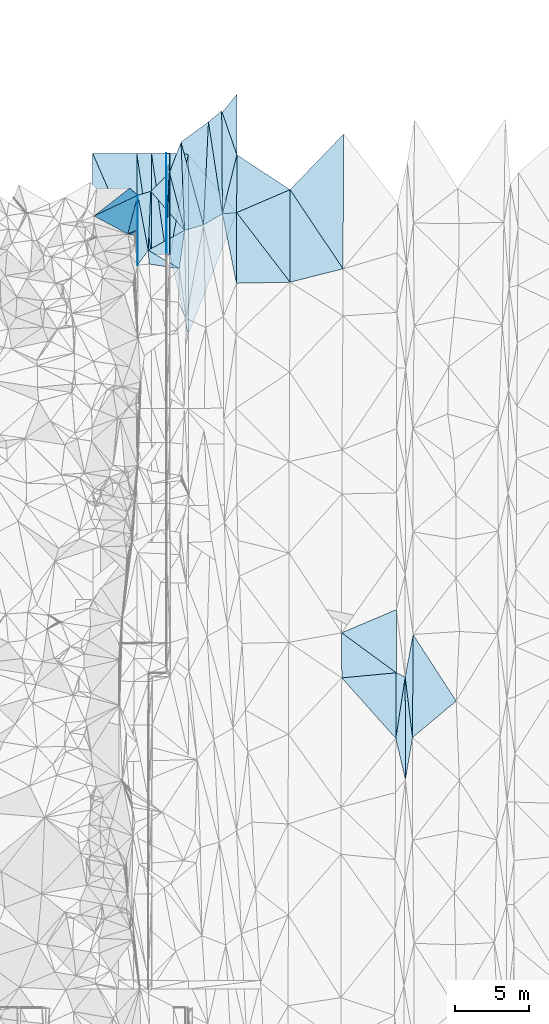
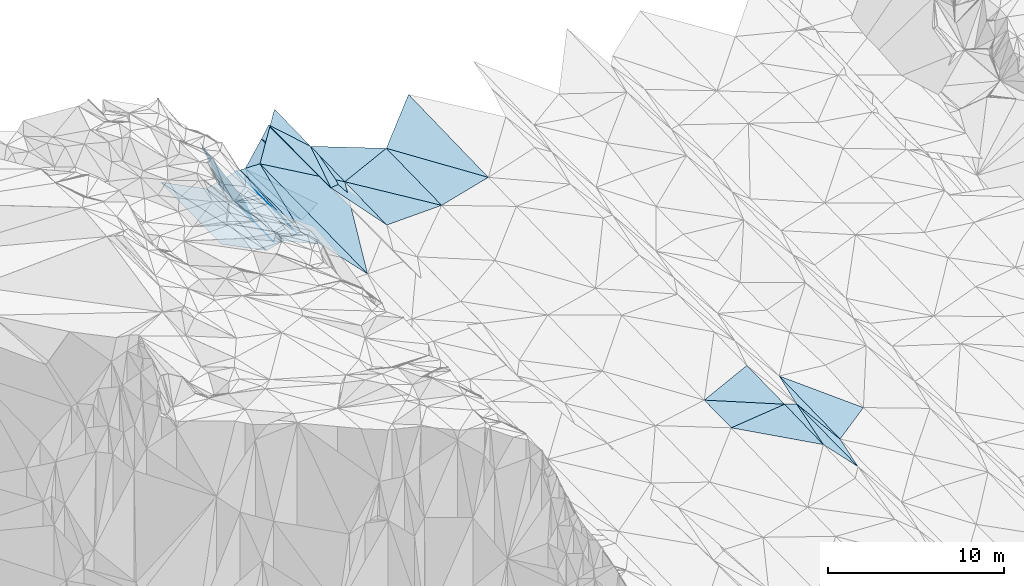
# One storey, part 144 of 275: 46 plates.
"""IFC2X3 building model written with IfcOpenShell, lengths in millimetres."""

from ifc_helpers import new_model, si_unit, frame, origin_with_axes, place, context, subcontext, project, spatial, polyline, outline, extrude, material, type_object, element, save


model = new_model("IFC2X3")

# Units and contexts
model_context = context("Model", 3, precision=1e-05, world=origin_with_axes())
body_context = subcontext(model_context, "Body", "Model", "MODEL_VIEW")
ifc_project = project(units=[si_unit("LENGTHUNIT", "METRE", prefix="MILLI"), si_unit("AREAUNIT", "SQUARE_METRE"), si_unit("VOLUMEUNIT", "CUBIC_METRE"), si_unit("MASSUNIT", "GRAM", prefix="KILO"), si_unit("TIMEUNIT", "SECOND"), si_unit("PLANEANGLEUNIT", "RADIAN"), si_unit("SOLIDANGLEUNIT", "STERADIAN"), si_unit("THERMODYNAMICTEMPERATUREUNIT", "DEGREE_CELSIUS"), si_unit("LUMINOUSINTENSITYUNIT", "LUMEN")], contexts=[model_context])

# Site, building, storey
site_placement = place(None, origin_with_axes())
site = spatial("IfcSite", under=ifc_project, at=site_placement, CompositionType="ELEMENT")
building_placement = place(site_placement, origin_with_axes())
building = spatial("IfcBuilding", under=site, at=building_placement, Name="Undefined", CompositionType="ELEMENT")
storey_placement = place(building_placement, origin_with_axes())
storey = spatial("IfcBuildingStorey", under=building, at=storey_placement, Name="Undefined", CompositionType="ELEMENT", Elevation=0.0)

# Plates
ifc_material = material()
plate_type_1 = type_object("IfcPlateType", PredefinedType="NOTDEFINED")
plate_1_placement = place(storey_placement, frame((-97590.6095144103, 136042.958184451, 44252.5008108323), z_axis=(0.0514832907805733, 0.0259882648043825, -0.998335655409973), x_axis=(-0.00443610332481202, -0.999645536783558, -0.0262511290424581)))
element("IfcPlate", 1, at=plate_1_placement, inside=storey, type_object=plate_type_1, material=ifc_material, Name="00", context=body_context, shape_type="SweptSolid", body=[
    extrude(outline(polyline([(0.0, 0.0), (4761.69970703125, 4.69444785267115e-08), (2378.60620117188, 10.8841924667358), (0.0, 0.0)])), frame((-8.85201319254618e-08, 2.18876761149539e-07, -0.5000001331573), z_axis=(0.0, 0.0, 1.0), x_axis=(1.0, 0.0, 0.0)), (0.0, 0.0, 1.0), 1.0),
])
plate_type_2 = type_object("IfcPlateType", PredefinedType="NOTDEFINED")
plate_2_placement = place(storey_placement, frame((-95411.9132426527, 131994.505825985, 43613.0622129509), z_axis=(0.0224822411046285, 0.0189781008891617, -0.999567096558082), x_axis=(0.179724849015763, 0.983454639409164, 0.0227145519624127)))
element("IfcPlate", 2, at=plate_2_placement, inside=storey, type_object=plate_type_2, material=ifc_material, Name="00_PR", context=body_context, shape_type="SweptSolid", body=[
    extrude(outline(polyline([(0.0, 0.0), (6942.90625, 5.26488292962313e-08), (-5108.5693359375, 2206.3701171875), (0.0, 0.0)])), frame((-8.85201319254618e-08, 2.18876761149539e-07, -0.5000001331573), z_axis=(0.0, 0.0, 1.0), x_axis=(1.0, 0.0, 0.0)), (0.0, 0.0, 1.0), 1.0),
])
plate_type_3 = type_object("IfcPlateType", PredefinedType="NOTDEFINED")
plate_3_placement = place(storey_placement, frame((-95664.109131725, 138888.552584876, 43729.3927088846), z_axis=(0.0499222322961073, 0.0186763581657816, -0.998578471812925), x_axis=(0.998752315665235, 0.000325866070990781, 0.0499370179790064)))
element("IfcPlate", 3, at=plate_3_placement, inside=storey, type_object=plate_type_3, material=ifc_material, Name="00_PR", context=body_context, shape_type="SweptSolid", body=[
    extrude(outline(polyline([(0.0, 0.0), (20.0252170562744, 7.18500814400613e-11), (13.5525465011597, 6895.32861328125), (0.0, 0.0)])), frame((-8.85201319254618e-08, 2.18876761149539e-07, -0.5000001331573), z_axis=(0.0, 0.0, 1.0), x_axis=(1.0, 0.0, 0.0)), (0.0, 0.0, 1.0), 1.0),
])
plate_4_placement = place(storey_placement, frame((-95641.8988715863, 131994.431588011, 43601.5627079431), z_axis=(0.0499222322961073, 0.0186763581657816, -0.998578471812925), x_axis=(-0.998752315521962, -0.000325847078123489, -0.0499370209684242)))
element("IfcPlate", 4, at=plate_4_placement, inside=storey, type_object=plate_type_3, material=ifc_material, Name="00_PR", context=body_context, shape_type="SweptSolid", body=[
    extrude(outline(polyline([(0.0, 0.0), (20.0252170562744, 7.18500814400613e-11), (13.5523777008057, 6895.32861328125), (0.0, 0.0)])), frame((-8.85201319254618e-08, 2.18876761149539e-07, -0.5000001331573), z_axis=(0.0, 0.0, 1.0), x_axis=(1.0, 0.0, 0.0)), (0.0, 0.0, 1.0), 1.0),
])
plate_type_4 = type_object("IfcPlateType", PredefinedType="NOTDEFINED")
plate_5_placement = place(storey_placement, frame((-96661.8032589634, 131994.104718569, 43350.5770069072), z_axis=(0.242490143071299, 0.0182037295266078, -0.969983069308214), x_axis=(-0.970142403271045, -0.000311047105442569, -0.242535813077531)))
element("IfcPlate", 5, at=plate_5_placement, inside=storey, type_object=plate_type_4, material=ifc_material, Name="00_PR", context=body_context, shape_type="SweptSolid", body=[
    extrude(outline(polyline([(0.0, 0.0), (1030.77563476563, 6.37373887002468e-09), (999.529357910156, 6895.2607421875), (0.0, 0.0)])), frame((-8.85201319254618e-08, 2.18876761149539e-07, -0.5000001331573), z_axis=(0.0, 0.0, 1.0), x_axis=(1.0, 0.0, 0.0)), (0.0, 0.0, 1.0), 1.0),
])
plate_6_placement = place(storey_placement, frame((-97664.0124157105, 138887.911618985, 43229.4070067982), z_axis=(0.242490143071299, 0.0182037295266078, -0.969983069308214), x_axis=(0.970142455388523, 0.000311440077304942, 0.242535604103411)))
element("IfcPlate", 6, at=plate_6_placement, inside=storey, type_object=plate_type_4, material=ifc_material, Name="00_PR", context=body_context, shape_type="SweptSolid", body=[
    extrude(outline(polyline([(0.0, 0.0), (1030.77648925781, -5.90807758271694e-09), (999.526672363281, 6895.26123046875), (0.0, 0.0)])), frame((-8.85201319254618e-08, 2.18876761149539e-07, -0.5000001331573), z_axis=(0.0, 0.0, 1.0), x_axis=(1.0, 0.0, 0.0)), (0.0, 0.0, 1.0), 1.0),
])
plate_7_placement = place(storey_placement, frame((-95661.8028117827, 131994.424829902, 43600.5770067178), z_axis=(0.242490143071299, 0.0182037295266078, -0.969983069308214), x_axis=(-0.970142403271045, -0.000311047105442569, -0.242535813077531)))
element("IfcPlate", 7, at=plate_7_placement, inside=storey, type_object=plate_type_4, material=ifc_material, Name="00_PR", context=body_context, shape_type="SweptSolid", body=[
    extrude(outline(polyline([(0.0, 0.0), (1030.77685546875, 5.06406649947166e-09), (999.533203125, 6895.26123046875), (0.0, 0.0)])), frame((-8.85201319254618e-08, 2.18876761149539e-07, -0.5000001331573), z_axis=(0.0, 0.0, 1.0), x_axis=(1.0, 0.0, 0.0)), (0.0, 0.0, 1.0), 1.0),
])
plate_8_placement = place(storey_placement, frame((-95661.8028117827, 131994.424829902, 43600.5770067178), z_axis=(0.242490143071299, 0.0182037295266078, -0.969983069308214), x_axis=(-0.143844128027655, 0.989447529773954, -0.0173911660386578)))
element("IfcPlate", 8, at=plate_8_placement, inside=storey, type_object=plate_type_4, material=ifc_material, Name="00_PR", context=body_context, shape_type="SweptSolid", body=[
    extrude(outline(polyline([(0.0, 0.0), (6967.33056640625, 9.51258698478341e-08), (6819.455078125, 1020.11370849609), (0.0, 0.0)])), frame((-8.85201319254618e-08, 2.18876761149539e-07, -0.5000001331573), z_axis=(0.0, 0.0, 1.0), x_axis=(1.0, 0.0, 0.0)), (0.0, 0.0, 1.0), 1.0),
])
plate_type_5 = type_object("IfcPlateType", PredefinedType="NOTDEFINED")
for number, where, z_axis, x_axis, name in (
    (9, (-95414.1095565633, 138888.633197667, 43741.8927079648), (0.0499222322961073, 0.0186763581657816, -0.998578471812925), (-0.0330158579091699, -0.999247846554918, -0.020339475949028), "00_PR"),
    (10, (-95641.8988715863, 131994.431588011, 43601.5627079431), (0.0499222322961073, 0.0186763581657816, -0.998578471812925), (0.0330158579192663, 0.999247846554812, 0.0203394759378399), "00_PR"),
):
    element("IfcPlate", number, at=place(storey_placement, frame(where, z_axis=z_axis, x_axis=x_axis)), inside=storey, type_object=plate_type_5, material=ifc_material, Name=name, context=body_context, shape_type="SweptSolid", body=[
        extrude(outline(polyline([(0.0, 0.0), (6899.39111328125, -1.00917532108724e-07), (7.90156173706055, 230.151077270508), (0.0, 0.0)])), frame((-8.85201319254618e-08, 2.18876761149539e-07, -0.5000001331573), z_axis=(0.0, 0.0, 1.0), x_axis=(1.0, 0.0, 0.0)), (0.0, 0.0, 1.0), 1.0),
    ])
plate_type_6 = type_object("IfcPlateType", PredefinedType="NOTDEFINED")
for number, where, z_axis, x_axis, name in (
    (11, (-97662.1472010932, 131993.783279259, 43100.6148477976), (-0.447156504533022, 0.0165684101290728, -0.894302268944681), (-0.894427130836978, -0.000286740047867567, 0.447213623901237), "00_PR"),
    (12, (-100664.356840001, 138886.949043185, 44729.444847469), (-0.447156504533022, 0.0165684101290728, -0.894302268944681), (0.894427130836624, 0.000286740053144665, -0.447213623901941), "00_PR"),
):
    element("IfcPlate", number, at=place(storey_placement, frame(where, z_axis=z_axis, x_axis=x_axis)), inside=storey, type_object=plate_type_6, material=ifc_material, Name=name, context=body_context, shape_type="SweptSolid", body=[
        extrude(outline(polyline([(0.0, 0.0), (3354.10180664063, 1.95868778973818e-08), (3411.71606445313, 6895.0908203125), (0.0, 0.0)])), frame((-8.85201319254618e-08, 2.18876761149539e-07, -0.5000001331573), z_axis=(0.0, 0.0, 1.0), x_axis=(1.0, 0.0, 0.0)), (0.0, 0.0, 1.0), 1.0),
    ])
plate_type_7 = type_object("IfcPlateType", PredefinedType="NOTDEFINED")
plate_9_placement = place(storey_placement, frame((-91839.4435066399, 134774.05361449, 43750.5001838916), z_axis=(0.0196335988798624, 0.0198434004688057, -0.999610304695214), x_axis=(-0.00718574764205393, 0.999780002348236, 0.0197056320727402)))
element("IfcPlate", 13, at=plate_9_placement, inside=storey, type_object=plate_type_7, material=ifc_material, Name="00", context=body_context, shape_type="SweptSolid", body=[
    extrude(outline(polyline([(0.0, 0.0), (7003.07373046875, -3.53320501744747e-08), (4009.10107421875, 1011.44342041016), (0.0, 0.0)])), frame((-8.85201319254618e-08, 2.18876761149539e-07, -0.5000001331573), z_axis=(0.0, 0.0, 1.0), x_axis=(1.0, 0.0, 0.0)), (0.0, 0.0, 1.0), 1.0),
])
plate_type_8 = type_object("IfcPlateType", PredefinedType="NOTDEFINED")
plate_10_placement = place(storey_placement, frame((-94658.0630558945, 139653.042814723, 43102.5198783375), z_axis=(-0.279275839807547, -0.0045945426057969, -0.960199924743818), x_axis=(0.0410621335987805, -0.999130924627875, -0.00716216702990464)))
element("IfcPlate", 14, at=plate_10_placement, inside=storey, type_object=plate_type_8, material=ifc_material, Name="00", context=body_context, shape_type="SweptSolid", body=[
    extrude(outline(polyline([(0.0, 0.0), (6003.76904296875, 4.33647073805332e-09), (2039.29577636719, 901.096496582031), (0.0, 0.0)])), frame((-8.85201319254618e-08, 2.18876761149539e-07, -0.5000001331573), z_axis=(0.0, 0.0, 1.0), x_axis=(1.0, 0.0, 0.0)), (0.0, 0.0, 1.0), 1.0),
])
plate_type_9 = type_object("IfcPlateType", PredefinedType="NOTDEFINED")
plate_11_placement = place(storey_placement, frame((-91839.4443426398, 134774.053015338, 43750.5001510048), z_axis=(0.0179408665255958, 0.0186484033596667, -0.999665125109627), x_axis=(0.996024567267398, 0.0869190966148841, 0.0194969752383364)))
element("IfcPlate", 15, at=plate_11_placement, inside=storey, type_object=plate_type_9, material=ifc_material, Name="00", context=body_context, shape_type="SweptSolid", body=[
    extrude(outline(polyline([(0.0, 0.0), (974.510131835938, 1.48429535329342e-09), (537.387939453125, 4788.603515625), (0.0, 0.0)])), frame((-8.85201319254618e-08, 2.18876761149539e-07, -0.5000001331573), z_axis=(0.0, 0.0, 1.0), x_axis=(1.0, 0.0, 0.0)), (0.0, 0.0, 1.0), 1.0),
])
plate_type_10 = type_object("IfcPlateType", PredefinedType="NOTDEFINED")
plate_12_placement = place(storey_placement, frame((-94164.0996812008, 138822.538933066, 43770.7672285281), z_axis=(0.0240768579966762, 0.018685956380727, -0.99953546207383), x_axis=(-0.179724849997843, -0.983454639229889, -0.0227145519538038)))
element("IfcPlate", 16, at=plate_12_placement, inside=storey, type_object=plate_type_10, material=ifc_material, Name="00_PR", context=body_context, shape_type="SweptSolid", body=[
    extrude(outline(polyline([(0.0, 0.0), (6942.90625, 5.26488292962313e-08), (160.315322875977, 1241.79638671875), (0.0, 0.0)])), frame((-8.85201319254618e-08, 2.18876761149539e-07, -0.5000001331573), z_axis=(0.0, 0.0, 1.0), x_axis=(1.0, 0.0, 0.0)), (0.0, 0.0, 1.0), 1.0),
])
plate_type_11 = type_object("IfcPlateType", PredefinedType="NOTDEFINED")
plate_13_placement = place(storey_placement, frame((-90844.8626261416, 142916.512635845, 43929.5002325346), z_axis=(0.0237940521133087, 0.0194627262058654, -0.999527411016159), x_axis=(-0.00297079593182855, -0.999804684861091, -0.0195388459573693)))
element("IfcPlate", 17, at=plate_13_placement, inside=storey, type_object=plate_type_11, material=ifc_material, Name="00_PR", context=body_context, shape_type="SweptSolid", body=[
    extrude(outline(polyline([(0.0, 0.0), (8059.32958984375, -6.73171598464251e-08), (4106.1357421875, 3307.98974609375), (0.0, 0.0)])), frame((-8.85201319254618e-08, 2.18876761149539e-07, -0.5000001331573), z_axis=(0.0, 0.0, 1.0), x_axis=(1.0, 0.0, 0.0)), (0.0, 0.0, 1.0), 1.0),
])
plate_type_12 = type_object("IfcPlateType", PredefinedType="NOTDEFINED")
plate_14_placement = place(storey_placement, frame((-97612.5112392918, 133665.375917615, 44189.8380881804), z_axis=(-0.909191183054947, 0.261796522097543, -0.323780749385719), x_axis=(-0.394577245516921, -0.79004158397243, 0.469194088746452)))
element("IfcPlate", 18, at=plate_14_placement, inside=storey, type_object=plate_type_12, material=ifc_material, Name="00", context=body_context, shape_type="SweptSolid", body=[
    extrude(outline(polyline([(0.0, 0.0), (426.262817382813, -3.21597326546907e-09), (1256.50170898438, 1315.06774902344), (0.0, 0.0)])), frame((-8.85201319254618e-08, 2.18876761149539e-07, -0.5000001331573), z_axis=(0.0, 0.0, 1.0), x_axis=(1.0, 0.0, 0.0)), (0.0, 0.0, 1.0), 1.0),
])
plate_type_13 = type_object("IfcPlateType", PredefinedType="NOTDEFINED")
plate_15_placement = place(storey_placement, frame((-94160.1729756144, 126572.965078749, 43538.2812219299), z_axis=(0.0232110253075902, 0.0189780183014569, -0.999550440510893), x_axis=(-0.00032053708407129, 0.999819893985314, 0.0189756909537742)))
element("IfcPlate", 19, at=plate_15_placement, inside=storey, type_object=plate_type_13, material=ifc_material, Name="00_PR", context=body_context, shape_type="SweptSolid", body=[
    extrude(outline(polyline([(0.0, 0.0), (12251.7802734375, 2.11875885725021e-08), (8287.6796875, 3294.91186523438), (0.0, 0.0)])), frame((-8.85201319254618e-08, 2.18876761149539e-07, -0.5000001331573), z_axis=(0.0, 0.0, 1.0), x_axis=(1.0, 0.0, 0.0)), (0.0, 0.0, 1.0), 1.0),
])
plate_16_placement = place(storey_placement, frame((-90857.0285554111, 138789.146828315, 43849.500208913), z_axis=(0.0215776027165981, 0.0202806304803427, -0.999561455383472), x_axis=(0.836441395376143, -0.548012467490554, 0.00693740413458254)))
element("IfcPlate", 20, at=plate_16_placement, inside=storey, type_object=plate_type_13, material=ifc_material, Name="00", context=body_context, shape_type="SweptSolid", body=[
    extrude(outline(polyline([(0.0, 0.0), (4324.38427734375, 2.11730366572738e-08), (2143.49584960938, 3295.44018554688), (0.0, 0.0)])), frame((-8.85201319254618e-08, 2.18876761149539e-07, -0.5000001331573), z_axis=(0.0, 0.0, 1.0), x_axis=(1.0, 0.0, 0.0)), (0.0, 0.0, 1.0), 1.0),
])
plate_type_14 = type_object("IfcPlateType", PredefinedType="NOTDEFINED")
plate_17_placement = place(storey_placement, frame((-80042.7242166052, 99093.0857115112, 43389.5000978887), z_axis=(0.00415664696816928, 0.0204408613140596, -0.9997824230675), x_axis=(0.150640428347545, 0.988369067621035, 0.0208338070739579)))
element("IfcPlate", 21, at=plate_17_placement, inside=storey, type_object=plate_type_14, material=ifc_material, Name="00", context=body_context, shape_type="SweptSolid", body=[
    extrude(outline(polyline([(0.0, 0.0), (4223.90380859375, 2.25991243496537e-08), (-2692.8466796875, 1071.09924316406), (0.0, 0.0)])), frame((-8.85201319254618e-08, 2.18876761149539e-07, -0.5000001331573), z_axis=(0.0, 0.0, 1.0), x_axis=(1.0, 0.0, 0.0)), (0.0, 0.0, 1.0), 1.0),
])
plate_type_15 = type_object("IfcPlateType", PredefinedType="NOTDEFINED")
plate_18_placement = place(storey_placement, frame((-90868.8083930978, 134858.757381268, 43769.5001714335), z_axis=(0.0177967312019449, 0.0202934711828925, -0.999635659320872), x_axis=(-0.996024567263042, -0.0869190966691805, -0.019496975218805)))
element("IfcPlate", 22, at=plate_18_placement, inside=storey, type_object=plate_type_15, material=ifc_material, Name="00", context=body_context, shape_type="SweptSolid", body=[
    extrude(outline(polyline([(0.0, 0.0), (974.510131835938, 1.48429535329342e-09), (-354.916778564453, 3915.16723632813), (0.0, 0.0)])), frame((-8.85201319254618e-08, 2.18876761149539e-07, -0.5000001331573), z_axis=(0.0, 0.0, 1.0), x_axis=(1.0, 0.0, 0.0)), (0.0, 0.0, 1.0), 1.0),
])
plate_type_16 = type_object("IfcPlateType", PredefinedType="NOTDEFINED")
plate_19_placement = place(storey_placement, frame((-93125.2942562179, 134025.110776209, 43554.5218896534), z_axis=(0.292696387843175, 0.00290503290278792, -0.956201017217296), x_axis=(-0.261947692630251, 0.961984524310232, -0.0772604770455356)))
element("IfcPlate", 23, at=plate_19_placement, inside=storey, type_object=plate_type_16, material=ifc_material, Name="00", context=body_context, shape_type="SweptSolid", body=[
    extrude(outline(polyline([(0.0, 0.0), (5850.33935546875, -4.67189238406718e-08), (6645.27490234375, 2257.69946289063), (0.0, 0.0)])), frame((-8.85201319254618e-08, 2.18876761149539e-07, -0.5000001331573), z_axis=(0.0, 0.0, 1.0), x_axis=(1.0, 0.0, 0.0)), (0.0, 0.0, 1.0), 1.0),
])
plate_type_17 = type_object("IfcPlateType", PredefinedType="NOTDEFINED")
plate_20_placement = place(storey_placement, frame((-91889.6701860979, 141775.587379356, 43888.5113460552), z_axis=(0.210888014134736, 0.0207780639379609, -0.977289372475368), x_axis=(0.00718574754794233, -0.999780002349323, -0.0197056320519184)))
element("IfcPlate", 24, at=plate_20_placement, inside=storey, type_object=plate_type_17, material=ifc_material, Name="00", context=body_context, shape_type="SweptSolid", body=[
    extrude(outline(polyline([(0.0, 0.0), (7003.07373046875, -3.53320501744747e-08), (738.771423339844, 926.305419921875), (0.0, 0.0)])), frame((-8.85201319254618e-08, 2.18876761149539e-07, -0.5000001331573), z_axis=(0.0, 0.0, 1.0), x_axis=(1.0, 0.0, 0.0)), (0.0, 0.0, 1.0), 1.0),
])
plate_type_18 = type_object("IfcPlateType", PredefinedType="NOTDEFINED")
plate_21_placement = place(storey_placement, frame((-96888.9161107412, 132301.242019015, 43829.5249588471), z_axis=(-0.310836993025376, 0.0284706518444846, -0.950036728632369), x_axis=(0.846668480780187, 0.462494460538026, -0.263156526852385)))
element("IfcPlate", 25, at=plate_21_placement, inside=storey, type_object=plate_type_18, material=ifc_material, Name="00", context=body_context, shape_type="SweptSolid", body=[
    extrude(outline(polyline([(0.0, 0.0), (2926.01513671875, 2.65426933765411e-08), (1405.56005859375, 2145.27416992188), (0.0, 0.0)])), frame((-8.85201319254618e-08, 2.18876761149539e-07, -0.5000001331573), z_axis=(0.0, 0.0, 1.0), x_axis=(1.0, 0.0, 0.0)), (0.0, 0.0, 1.0), 1.0),
])
plate_type_19 = type_object("IfcPlateType", PredefinedType="NOTDEFINED")
plate_22_placement = place(storey_placement, frame((-98153.1395398743, 136520.365499255, 45099.7614733313), z_axis=(-0.862476378123854, -0.16910093196392, -0.47701087198018), x_axis=(0.500467226379932, -0.425168105583981, -0.754164860831971)))
element("IfcPlate", 26, at=plate_22_placement, inside=storey, type_object=plate_type_19, material=ifc_material, Name="00", context=body_context, shape_type="SweptSolid", body=[
    extrude(outline(polyline([(0.0, 0.0), (1123.09655761719, -4.83123585581779e-09), (-4216.85009765625, 4142.89453125), (0.0, 0.0)])), frame((-8.85201319254618e-08, 2.18876761149539e-07, -0.5000001331573), z_axis=(0.0, 0.0, 1.0), x_axis=(1.0, 0.0, 0.0)), (0.0, 0.0, 1.0), 1.0),
])
plate_type_20 = type_object("IfcPlateType", PredefinedType="NOTDEFINED")
plate_23_placement = place(storey_placement, frame((-80014.6705131621, 103555.485473126, 43479.5001003353), z_axis=(0.00622920743705572, 0.0201248843748113, -0.99977806837498), x_axis=(0.90401477030659, -0.427490887507445, -0.0029725688590081)))
element("IfcPlate", 27, at=plate_23_placement, inside=storey, type_object=plate_type_20, material=ifc_material, Name="00", context=body_context, shape_type="SweptSolid", body=[
    extrude(outline(polyline([(0.0, 0.0), (672.818725585938, -2.895831130445e-09), (1882.54284667969, 4046.9658203125), (0.0, 0.0)])), frame((-8.85201319254618e-08, 2.18876761149539e-07, -0.5000001331573), z_axis=(0.0, 0.0, 1.0), x_axis=(1.0, 0.0, 0.0)), (0.0, 0.0, 1.0), 1.0),
])
plate_type_21 = type_object("IfcPlateType", PredefinedType="NOTDEFINED")
plate_24_placement = place(storey_placement, frame((-79389.5654890542, 96270.1506151824, 43334.5031004654), z_axis=(-0.109563715443802, 0.0200431054441798, -0.993777674423361), x_axis=(-0.00241811754279714, 0.999788342524316, 0.0204309290055511)))
element("IfcPlate", 28, at=plate_24_placement, inside=storey, type_object=plate_type_21, material=ifc_material, Name="00", context=body_context, shape_type="SweptSolid", body=[
    extrude(outline(polyline([(0.0, 0.0), (6999.1923828125, 9.86619852483273e-09), (2880.2587890625, 491.783264160156), (0.0, 0.0)])), frame((-8.85201319254618e-08, 2.18876761149539e-07, -0.5000001331573), z_axis=(0.0, 0.0, 1.0), x_axis=(1.0, 0.0, 0.0)), (0.0, 0.0, 1.0), 1.0),
])
plate_type_22 = type_object("IfcPlateType", PredefinedType="NOTDEFINED")
plate_25_placement = place(storey_placement, frame((-96888.9202136519, 132301.251365189, 43829.5266942122), z_axis=(-0.319042410978166, 0.0471627727573529, -0.946566222122403), x_axis=(-0.183237659580165, 0.976846300744676, 0.110432172997841)))
element("IfcPlate", 29, at=plate_25_placement, inside=storey, type_object=plate_type_22, material=ifc_material, Name="00", context=body_context, shape_type="SweptSolid", body=[
    extrude(outline(polyline([(0.0, 0.0), (3830.40551757813, -1.41153577715158e-08), (3893.619140625, 956.990112304688), (0.0, 0.0)])), frame((-8.85201319254618e-08, 2.18876761149539e-07, -0.5000001331573), z_axis=(0.0, 0.0, 1.0), x_axis=(1.0, 0.0, 0.0)), (0.0, 0.0, 1.0), 1.0),
])
plate_type_23 = type_object("IfcPlateType", PredefinedType="NOTDEFINED")
plate_26_placement = place(storey_placement, frame((-96888.9379024528, 132301.200321659, 43829.5332408472), z_axis=(-0.354416672011984, -0.0549274030206771, -0.933472979254008), x_axis=(0.825264983417368, -0.487773285521667, -0.284631215920757)))
element("IfcPlate", 30, at=plate_26_placement, inside=storey, type_object=plate_type_23, material=ifc_material, Name="00", context=body_context, shape_type="SweptSolid", body=[
    extrude(outline(polyline([(0.0, 0.0), (2564.72216796875, 2.6775524020195e-09), (507.072448730469, 798.922729492188), (0.0, 0.0)])), frame((-8.85201319254618e-08, 2.18876761149539e-07, -0.5000001331573), z_axis=(0.0, 0.0, 1.0), x_axis=(1.0, 0.0, 0.0)), (0.0, 0.0, 1.0), 1.0),
])
plate_type_24 = type_object("IfcPlateType", PredefinedType="NOTDEFINED")
plate_27_placement = place(storey_placement, frame((-78907.7147384678, 99152.0818027592, 43339.5037407283), z_axis=(-0.12081887077549, 0.0186362673157797, -0.992499617130944), x_axis=(-0.120240752579118, 0.992187196248378, 0.0332675370292124)))
element("IfcPlate", 31, at=plate_27_placement, inside=storey, type_object=plate_type_24, material=ifc_material, Name="00", context=body_context, shape_type="SweptSolid", body=[
    extrude(outline(polyline([(0.0, 0.0), (4148.18798828125, -2.05182004719973e-09), (6949.14501953125, 885.635559082031), (0.0, 0.0)])), frame((-8.85201319254618e-08, 2.18876761149539e-07, -0.5000001331573), z_axis=(0.0, 0.0, 1.0), x_axis=(1.0, 0.0, 0.0)), (0.0, 0.0, 1.0), 1.0),
])
plate_type_25 = type_object("IfcPlateType", PredefinedType="NOTDEFINED")
plate_28_placement = place(storey_placement, frame((-97591.0996566521, 136042.954280135, 44252.8149169243), z_axis=(-0.928804380373739, 0.0181747575504518, -0.370124440136741), x_axis=(-0.00900576534029415, -0.999608622122313, -0.0264858220443624)))
element("IfcPlate", 32, at=plate_28_placement, inside=storey, type_object=plate_type_25, material=ifc_material, Name="00", context=body_context, shape_type="SweptSolid", body=[
    extrude(outline(polyline([(0.0, 0.0), (2378.63110351563, 2.24972609430552e-08), (2604.025390625, 1804.826171875), (0.0, 0.0)])), frame((-8.85201319254618e-08, 2.18876761149539e-07, -0.5000001331573), z_axis=(0.0, 0.0, 1.0), x_axis=(1.0, 0.0, 0.0)), (0.0, 0.0, 1.0), 1.0),
])
plate_type_26 = type_object("IfcPlateType", PredefinedType="NOTDEFINED")
plate_29_placement = place(storey_placement, frame((-97611.9645357946, 131282.946013518, 44127.5445116092), z_axis=(-0.411730832508176, 0.0257488547654292, -0.910941665552956), x_axis=(0.00443610344471275, 0.999645536783989, 0.0262511290057862)))
element("IfcPlate", 33, at=plate_29_placement, inside=storey, type_object=plate_type_26, material=ifc_material, Name="00", context=body_context, shape_type="SweptSolid", body=[
    extrude(outline(polyline([(0.0, 0.0), (4761.69970703125, 4.69444785267115e-08), (1013.31817626953, 788.441711425781), (0.0, 0.0)])), frame((-8.85201319254618e-08, 2.18876761149539e-07, -0.5000001331573), z_axis=(0.0, 0.0, 1.0), x_axis=(1.0, 0.0, 0.0)), (0.0, 0.0, 1.0), 1.0),
])
plate_type_27 = type_object("IfcPlateType", PredefinedType="NOTDEFINED")
plate_30_placement = place(storey_placement, frame((-98283.1473999501, 133401.532031566, 45859.7699291887), z_axis=(-0.886589495464091, -0.04762559126539, -0.460098760690952), x_axis=(-0.45693518520579, 0.244784716672114, 0.855155353725101)))
element("IfcPlate", 34, at=plate_30_placement, inside=storey, type_object=plate_type_27, material=ifc_material, Name="00", context=body_context, shape_type="SweptSolid", body=[
    extrude(outline(polyline([(0.0, 0.0), (5016.63232421875, -2.57568899542093e-09), (-1043.8935546875, 2991.42651367188), (0.0, 0.0)])), frame((-8.85201319254618e-08, 2.18876761149539e-07, -0.5000001331573), z_axis=(0.0, 0.0, 1.0), x_axis=(1.0, 0.0, 0.0)), (0.0, 0.0, 1.0), 1.0),
])
plate_type_28 = type_object("IfcPlateType", PredefinedType="NOTDEFINED")
plate_31_placement = place(storey_placement, frame((-90868.8106322812, 134858.756567612, 43769.5001207638), z_axis=(0.013312909407171, 0.0186666566639812, -0.99973712663485), x_axis=(0.608938056232106, -0.793189471263826, -0.00670121992460197)))
element("IfcPlate", 35, at=plate_31_placement, inside=storey, type_object=plate_type_28, material=ifc_material, Name="00", context=body_context, shape_type="SweptSolid", body=[
    extrude(outline(polyline([(0.0, 0.0), (5969.06201171875, 4.28153725806624e-08), (3803.27758789063, 2942.25732421875), (0.0, 0.0)])), frame((-8.85201319254618e-08, 2.18876761149539e-07, -0.5000001331573), z_axis=(0.0, 0.0, 1.0), x_axis=(1.0, 0.0, 0.0)), (0.0, 0.0, 1.0), 1.0),
])
plate_type_29 = type_object("IfcPlateType", PredefinedType="NOTDEFINED")
plate_32_placement = place(storey_placement, frame((-83720.3458967658, 103207.390428425, 43349.5003897514), z_axis=(0.0328997058464592, 0.0229229028831488, -0.999195751531514), x_axis=(-0.00366295261575817, 0.999733002277646, 0.0228146210807646)))
element("IfcPlate", 36, at=plate_32_placement, inside=storey, type_object=plate_type_29, material=ifc_material, Name="00", context=body_context, shape_type="SweptSolid", body=[
    extrude(outline(polyline([(0.0, 0.0), (3068.2080078125, -1.41153577715158e-09), (337.395660400391, 3708.95727539063), (0.0, 0.0)])), frame((-8.85201319254618e-08, 2.18876761149539e-07, -0.5000001331573), z_axis=(0.0, 0.0, 1.0), x_axis=(1.0, 0.0, 0.0)), (0.0, 0.0, 1.0), 1.0),
])
plate_type_30 = type_object("IfcPlateType", PredefinedType="NOTDEFINED")
plate_33_placement = place(storey_placement, frame((-96712.5134050045, 136304.422679989, 43969.5268391182), z_axis=(-0.319894122139201, 0.0471902031415856, -0.946277356459641), x_axis=(0.634653239284308, -0.730900510377687, -0.2509974298585)))
element("IfcPlate", 37, at=plate_33_placement, inside=storey, type_object=plate_type_30, material=ifc_material, Name="00", context=body_context, shape_type="SweptSolid", body=[
    extrude(outline(polyline([(0.0, 0.0), (3625.53515625, 2.96258804155514e-08), (2849.10205078125, 2821.11987304688), (0.0, 0.0)])), frame((-8.85201319254618e-08, 2.18876761149539e-07, -0.5000001331573), z_axis=(0.0, 0.0, 1.0), x_axis=(1.0, 0.0, 0.0)), (0.0, 0.0, 1.0), 1.0),
])
plate_type_31 = type_object("IfcPlateType", PredefinedType="NOTDEFINED")
plate_34_placement = place(storey_placement, frame((-95438.8412139476, 137578.169981553, 43339.5441714925), z_axis=(-0.408898090879993, -0.0419974195934007, -0.911613167973232), x_axis=(0.252667099690781, -0.965099044244809, -0.0688706870272517)))
element("IfcPlate", 38, at=plate_34_placement, inside=storey, type_object=plate_type_31, material=ifc_material, Name="00", context=body_context, shape_type="SweptSolid", body=[
    extrude(outline(polyline([(0.0, 0.0), (4065.59033203125, -2.96859070658684e-09), (864.120483398438, 1701.498046875), (0.0, 0.0)])), frame((-8.85201319254618e-08, 2.18876761149539e-07, -0.5000001331573), z_axis=(0.0, 0.0, 1.0), x_axis=(1.0, 0.0, 0.0)), (0.0, 0.0, 1.0), 1.0),
])
plate_type_32 = type_object("IfcPlateType", PredefinedType="NOTDEFINED")
plate_35_placement = place(storey_placement, frame((-80014.6570356702, 103555.485382442, 43479.5003641616), z_axis=(0.0331813690520814, 0.019944807006205, -0.999250319700382), x_axis=(-0.00628505042658664, -0.99977693031764, -0.0201640210715153)))
element("IfcPlate", 39, at=plate_35_placement, inside=storey, type_object=plate_type_32, material=ifc_material, Name="00", context=body_context, shape_type="SweptSolid", body=[
    extrude(outline(polyline([(0.0, 0.0), (4463.3955078125, 1.40717020258307e-08), (373.930572509766, 3705.4521484375), (0.0, 0.0)])), frame((-8.85201319254618e-08, 2.18876761149539e-07, -0.5000001331573), z_axis=(0.0, 0.0, 1.0), x_axis=(1.0, 0.0, 0.0)), (0.0, 0.0, 1.0), 1.0),
])
plate_type_33 = type_object("IfcPlateType", PredefinedType="NOTDEFINED")
plate_36_placement = place(storey_placement, frame((-83590.4395608947, 140208.55200021, 44049.5002557098), z_axis=(0.0251886645383795, 0.0205805300571206, -0.999470846478946), x_axis=(-0.0049512513603167, -0.999773232938852, -0.0207115380636558)))
element("IfcPlate", 40, at=plate_36_placement, inside=storey, type_object=plate_type_33, material=ifc_material, Name="00", context=body_context, shape_type="SweptSolid", body=[
    extrude(outline(polyline([(0.0, 0.0), (9173.630859375, 3.27709130942822e-08), (3809.95288085938, 3631.82592773438), (0.0, 0.0)])), frame((-8.85201319254618e-08, 2.18876761149539e-07, -0.5000001331573), z_axis=(0.0, 0.0, 1.0), x_axis=(1.0, 0.0, 0.0)), (0.0, 0.0, 1.0), 1.0),
])
plate_type_34 = type_object("IfcPlateType", PredefinedType="NOTDEFINED")
plate_37_placement = place(storey_placement, frame((-75939.4551049919, 101633.14637516, 42985.5045677131), z_axis=(-0.13377808347234, 0.0186747418078237, -0.990835343738241), x_axis=(-0.764073569593355, -0.638661012310625, 0.0911245938440176)))
element("IfcPlate", 41, at=plate_37_placement, inside=storey, type_object=plate_type_34, material=ifc_material, Name="00", context=body_context, shape_type="SweptSolid", body=[
    extrude(outline(polyline([(0.0, 0.0), (3884.791015625, -1.27765815705061e-08), (-605.234130859375, 5377.2333984375), (0.0, 0.0)])), frame((-8.85201319254618e-08, 2.18876761149539e-07, -0.5000001331573), z_axis=(0.0, 0.0, 1.0), x_axis=(1.0, 0.0, 0.0)), (0.0, 0.0, 1.0), 1.0),
])
plate_type_35 = type_object("IfcPlateType", PredefinedType="NOTDEFINED")
plate_38_placement = place(storey_placement, frame((-93125.2637013203, 134025.119952855, 43554.5324459413), z_axis=(0.353813696526353, 0.0212439692904839, -0.935074629063982), x_axis=(-0.901219060136223, -0.259733715615421, -0.346904313348495)))
element("IfcPlate", 42, at=plate_38_placement, inside=storey, type_object=plate_type_35, material=ifc_material, Name="00", context=body_context, shape_type="SweptSolid", body=[
    extrude(outline(polyline([(0.0, 0.0), (1426.90649414063, 6.11180439591408e-10), (76.1388397216797, 5849.84375), (0.0, 0.0)])), frame((-8.85201319254618e-08, 2.18876761149539e-07, -0.5000001331573), z_axis=(0.0, 0.0, 1.0), x_axis=(1.0, 0.0, 0.0)), (0.0, 0.0, 1.0), 1.0),
])
plate_type_36 = type_object("IfcPlateType", PredefinedType="NOTDEFINED")
plate_39_placement = place(storey_placement, frame((-87239.9352445034, 136419.332068402, 43879.500232728), z_axis=(0.0200476241911865, 0.0238350755490937, -0.999514873294969), x_axis=(0.000939648654266877, -0.999715797646498, -0.0238210200544037)))
element("IfcPlate", 43, at=plate_39_placement, inside=storey, type_object=plate_type_36, material=ifc_material, Name="00", context=body_context, shape_type="SweptSolid", body=[
    extrude(outline(polyline([(0.0, 0.0), (6296.95947265625, -3.86789906769991e-08), (1559.33984375, 3631.06860351563), (0.0, 0.0)])), frame((-8.85201319254618e-08, 2.18876761149539e-07, -0.5000001331573), z_axis=(0.0, 0.0, 1.0), x_axis=(1.0, 0.0, 0.0)), (0.0, 0.0, 1.0), 1.0),
])
plate_type_37 = type_object("IfcPlateType", PredefinedType="NOTDEFINED")
plate_40_placement = place(storey_placement, frame((-80012.3117923988, 107853.449861471, 43569.5003450279), z_axis=(0.0314271383856453, 0.020908069400084, -0.999287339861189), x_axis=(-0.000545749383396809, -0.99978067829447, -0.0209355550836317)))
element("IfcPlate", 44, at=plate_40_placement, inside=storey, type_object=plate_type_37, material=ifc_material, Name="00", context=body_context, shape_type="SweptSolid", body=[
    extrude(outline(polyline([(0.0, 0.0), (4298.90673828125, 2.95985955744982e-08), (1583.49560546875, 3720.24755859375), (0.0, 0.0)])), frame((-8.85201319254618e-08, 2.18876761149539e-07, -0.5000001331573), z_axis=(0.0, 0.0, 1.0), x_axis=(1.0, 0.0, 0.0)), (0.0, 0.0, 1.0), 1.0),
])
plate_type_38 = type_object("IfcPlateType", PredefinedType="NOTDEFINED")
plate_41_placement = place(storey_placement, frame((-87239.9302282057, 136419.33206889, 43879.5003578922), z_axis=(0.0300552752023572, 0.0238385023125054, -0.999263932222117), x_axis=(0.556390720497256, -0.830915057677272, -0.00308756695790213)))
element("IfcPlate", 45, at=plate_41_placement, inside=storey, type_object=plate_type_38, material=ifc_material, Name="00", context=body_context, shape_type="SweptSolid", body=[
    extrude(outline(polyline([(0.0, 0.0), (6477.59228515625, -1.99843270820566e-08), (5234.5068359375, 3500.23413085938), (0.0, 0.0)])), frame((-8.85201319254618e-08, 2.18876761149539e-07, -0.5000001331573), z_axis=(0.0, 0.0, 1.0), x_axis=(1.0, 0.0, 0.0)), (0.0, 0.0, 1.0), 1.0),
])
plate_type_39 = type_object("IfcPlateType", PredefinedType="NOTDEFINED")
plate_42_placement = place(storey_placement, frame((-91839.3809997322, 134774.048981094, 43750.5052692739), z_axis=(0.144639039821788, 0.0105802386701175, -0.98942791890522), x_axis=(-0.856738293869734, -0.498947966588871, -0.130577266221988)))
element("IfcPlate", 46, at=plate_42_placement, inside=storey, type_object=plate_type_39, material=ifc_material, Name="00", context=body_context, shape_type="SweptSolid", body=[
    extrude(outline(polyline([(0.0, 0.0), (1501.02697753906, -1.23691279441118e-08), (-2299.84936523438, 5900.0185546875), (0.0, 0.0)])), frame((-8.85201319254618e-08, 2.18876761149539e-07, -0.5000001331573), z_axis=(0.0, 0.0, 1.0), x_axis=(1.0, 0.0, 0.0)), (0.0, 0.0, 1.0), 1.0),
])

save(model, "model.ifc")
